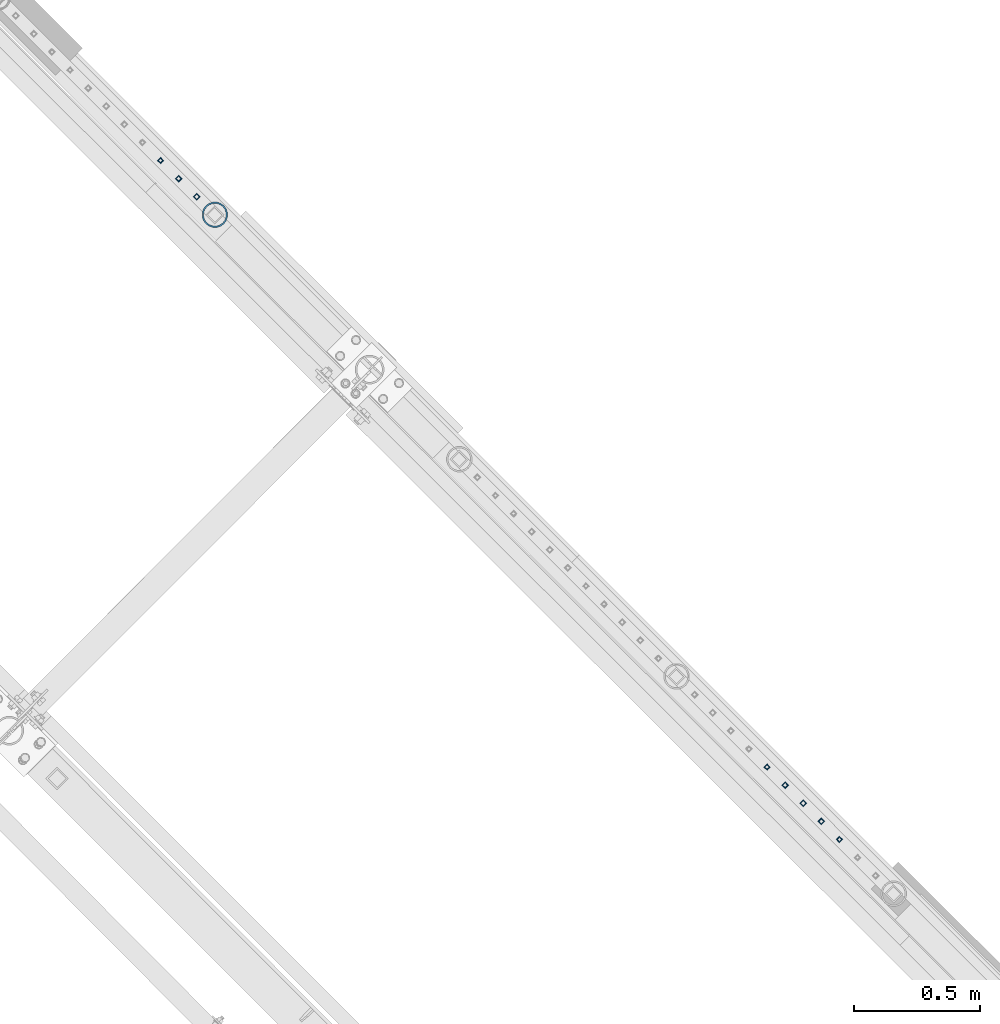
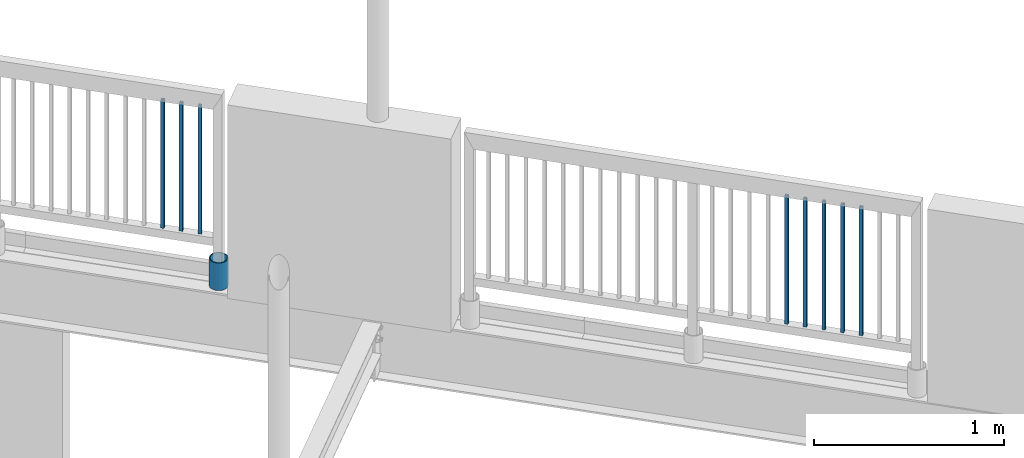
# One storey, part 283 of 975: 9 columns.
"""IFC2X3 building model written with IfcOpenShell, lengths in millimetres."""

import ifcopenshell
import ifcopenshell.guid

model = None  # the IFC model being written
_history = None  # IfcOwnerHistory: only IFC2X3 demands one
_inside = {}  # id of a spatial element -> (the spatial element, [elements in it])
_under = {}  # id of a project, library or spatial element -> (it, [spatial elements below it])
_declared = {}  # id of a project -> (the project, [libraries it declares])
_typed = {}  # id of a type object -> (the type object, [elements of that type])
_made_of = {}  # id of a material, layer set ... -> (it, [elements and type objects made of it])


def new_model(schema):
    """Start an empty IFC model of exactly this schema.

    Asked for "IFC4X3", IfcOpenShell would pick the latest addendum, in which some entities
    have other attributes; the version numbers below select the first issue.
    IFC2X3 requires an IfcOwnerHistory on every rooted entity: one is made here for all.
    """
    global model, _history
    if schema == "IFC4X3":
        model = ifcopenshell.file(schema_version=(4, 3, 0, 0))
    else:
        model = ifcopenshell.file(schema=schema)
    _inside.clear()
    _under.clear()
    _declared.clear()
    _typed.clear()
    _made_of.clear()
    _history = None
    if model.schema == "IFC2X3":
        org = make("IfcOrganization", Name="unknown")
        user = make(
            "IfcPersonAndOrganization",
            ThePerson=make("IfcPerson", FamilyName="unknown"),
            TheOrganization=org,
        )
        app = make(
            "IfcApplication",
            ApplicationDeveloper=org,
            Version="unknown",
            ApplicationFullName="unknown",
            ApplicationIdentifier="unknown",
        )
        _history = make(
            "IfcOwnerHistory",
            OwningUser=user,
            OwningApplication=app,
            ChangeAction="ADDED",
            CreationDate=0,
        )
    return model


def make(cls, **values):
    """One entity of the class cls with the attributes given. An attribute that is None is left unset."""
    return model.create_entity(
        cls, **{name: value for name, value in values.items() if value is not None}
    )


def rooted(cls, **values):
    """An entity with a GlobalId (a new one), such as an element, a storey or a relation."""
    return make(cls, GlobalId=ifcopenshell.guid.new(), OwnerHistory=_history, **values)


def si_unit(unit_type, name, prefix=None):
    """IfcSIUnit, for example si_unit("LENGTHUNIT", "METRE", prefix="MILLI")."""
    return make("IfcSIUnit", UnitType=unit_type, Prefix=prefix, Name=name)


def assignment(units):
    """IfcUnitAssignment: the units of a project."""
    return None if units is None else make("IfcUnitAssignment", Units=units)


def point(xyz):
    """IfcCartesianPoint."""
    return None if xyz is None else make("IfcCartesianPoint", Coordinates=xyz)


def direction(xyz):
    """IfcDirection."""
    return None if xyz is None else make("IfcDirection", DirectionRatios=xyz)


def frame(location, z_axis=None, x_axis=None):
    """IfcAxis2Placement3D, a coordinate frame: its origin and axes. An axis left out is left unset."""
    return make(
        "IfcAxis2Placement3D",
        Location=point(location),
        Axis=direction(z_axis),
        RefDirection=direction(x_axis),
    )


def origin_with_axes():
    """The frame at (0, 0, 0) with the z axis (0, 0, 1) and the x axis (1, 0, 0) written out."""
    return frame((0.0, 0.0, 0.0), z_axis=(0.0, 0.0, 1.0), x_axis=(1.0, 0.0, 0.0))


def place(relative_to, where):
    """IfcLocalPlacement: puts the frame where relative to a parent placement (None: the world)."""
    return make(
        "IfcLocalPlacement", PlacementRelTo=relative_to, RelativePlacement=where
    )


def context(
    kind, dimensions, precision=None, world=None, true_north=None, identifier=None
):
    """IfcGeometricRepresentationContext, for example the 3D "Model" context."""
    return make(
        "IfcGeometricRepresentationContext",
        ContextIdentifier=identifier,
        ContextType=kind,
        CoordinateSpaceDimension=dimensions,
        Precision=precision,
        WorldCoordinateSystem=world,
        TrueNorth=true_north,
    )


def subcontext(parent, identifier, kind, view, scale=None):
    """IfcGeometricRepresentationSubContext, for example "Body" below "Model"."""
    return make(
        "IfcGeometricRepresentationSubContext",
        ContextIdentifier=identifier,
        ContextType=kind,
        ParentContext=parent,
        TargetScale=scale,
        TargetView=view,
    )


def project(units=None, contexts=None):
    """IfcProject with its units and contexts."""
    return rooted(
        "IfcProject",
        Name="project",
        RepresentationContexts=contexts,
        UnitsInContext=assignment(units),
    )


def spatial(cls, under=None, at=None, **own):
    """A site, building, storey or space (cls), placed at a placement, below another one or the project."""
    s = rooted(cls, ObjectPlacement=at, **own)
    if under is not None:
        _under.setdefault(under.id(), (under, []))[1].append(s)
    return s


def faces_of(points, faces, orient=None, outer=None):
    """IfcFace entities. A face is a list of loops; a loop is a list of indices into points, from 0.

    orient and outer hold one flag for each loop. By default every Orientation is true, the
    first loop of a face is its IfcFaceOuterBound and the others are IfcFaceBound.
    """
    made = []
    for i, loops in enumerate(faces):
        bounds = []
        for j, loop in enumerate(loops):
            is_outer = j == 0 if outer is None else outer[i][j]
            bounds.append(
                make(
                    "IfcFaceOuterBound" if is_outer else "IfcFaceBound",
                    Bound=make("IfcPolyLoop", Polygon=[points[k] for k in loop]),
                    Orientation=True if orient is None else orient[i][j],
                )
            )
        made.append(make("IfcFace", Bounds=bounds))
    return made


def faceted_brep(points, faces, orient=None, outer=None, voids=None):
    """IfcFacetedBrep: a solid bounded by flat faces; with voids (closed shells), ...WithVoids."""
    shared = [point(p) for p in points]
    hull = make("IfcClosedShell", CfsFaces=faces_of(shared, faces, orient, outer))
    if voids is None:
        return make("IfcFacetedBrep", Outer=hull)
    return make(
        "IfcFacetedBrepWithVoids",
        Outer=hull,
        Voids=[
            make(cls, CfsFaces=faces_of(shared, fs, o, b)) for cls, fs, o, b in voids
        ],
    )


def shape(context_of_items, identifier, shape_type, items):
    """IfcShapeRepresentation: the items that make up one representation, for example the "Body"."""
    return make(
        "IfcShapeRepresentation",
        ContextOfItems=context_of_items,
        RepresentationIdentifier=identifier,
        RepresentationType=shape_type,
        Items=items,
    )


def material(Name=None, Category=None):
    """IfcMaterial."""
    return make("IfcMaterial", Name=Name, Category=Category)


def made_of(thing, what):
    """Note that an element or type object is made of a material, layer set ...; save() writes the relation."""
    if what is not None:
        _made_of.setdefault(what.id(), (what, []))[1].append(thing)
    return thing


def type_object(cls, material=None, **own):
    """A type object (cls), such as IfcWallType, which elements share."""
    return made_of(rooted(cls, **own), material)


def element(
    cls,
    number,
    at=None,
    inside=None,
    cuts=None,
    type_object=None,
    material=None,
    context=None,
    identifier="Body",
    shape_type=None,
    held_by="IfcProductDefinitionShape",
    body=None,
    shapes=None,
    **own,
):
    """One element of the class cls, such as IfcWall. Its Tag is "e" and its number.

    at: its placement. inside: the storey or other place that contains it. cuts: it is an
    opening in that element (IfcRelVoidsElement). A single representation is given by context,
    identifier, shape_type and body (its items); several are given by shapes. held_by: the class
    of the entity that holds the representations. save() writes the other relations.
    """
    e = rooted(cls, Tag="e%d" % number, ObjectPlacement=at, **own)
    if body is not None:
        shapes = [shape(context, identifier, shape_type, body)]
    if shapes is not None:
        e.Representation = make(held_by, Representations=shapes)
    if inside is not None:
        _inside.setdefault(inside.id(), (inside, []))[1].append(e)
    if cuts is not None:
        rooted(
            "IfcRelVoidsElement", RelatingBuildingElement=cuts, RelatedOpeningElement=e
        )
    if type_object is not None:
        _typed.setdefault(type_object.id(), (type_object, []))[1].append(e)
    return made_of(e, material)


def aggregate(whole, parts):
    """IfcRelAggregates: a whole, such as a stair, and the parts it consists of."""
    return rooted("IfcRelAggregates", RelatingObject=whole, RelatedObjects=parts)


def save(model, path):
    """Write the relations noted so far, then the file.

    IfcRelAggregates (storeys below a building ...), IfcRelContainedInSpatialStructure (elements
    in a storey), IfcRelDefinesByType, IfcRelAssociatesMaterial and IfcRelDeclares: one each for
    every whole, place, type object, material and project.
    """
    for whole, parts in _under.values():
        aggregate(whole, parts)
    for where, things in _inside.values():
        rooted(
            "IfcRelContainedInSpatialStructure",
            RelatedElements=things,
            RelatingStructure=where,
        )
    for kind, things in _typed.values():
        rooted("IfcRelDefinesByType", RelatedObjects=things, RelatingType=kind)
    for what, things in _made_of.values():
        rooted("IfcRelAssociatesMaterial", RelatedObjects=things, RelatingMaterial=what)
    for by, libraries in _declared.values():
        rooted("IfcRelDeclares", RelatingContext=by, RelatedDefinitions=libraries)
    model.write(path)


model = new_model("IFC2X3")

# Units and contexts
model_context = context("Model", 3, precision=1e-05, world=origin_with_axes())
body_context = subcontext(model_context, "Body", "Model", "MODEL_VIEW")
ifc_project = project(units=[si_unit("LENGTHUNIT", "METRE", prefix="MILLI"), si_unit("AREAUNIT", "SQUARE_METRE"), si_unit("VOLUMEUNIT", "CUBIC_METRE"), si_unit("MASSUNIT", "GRAM", prefix="KILO"), si_unit("TIMEUNIT", "SECOND"), si_unit("PLANEANGLEUNIT", "RADIAN"), si_unit("SOLIDANGLEUNIT", "STERADIAN"), si_unit("THERMODYNAMICTEMPERATUREUNIT", "DEGREE_CELSIUS"), si_unit("LUMINOUSINTENSITYUNIT", "LUMEN")], contexts=[model_context])

# Site, building, storey
site_placement = place(None, origin_with_axes())
site = spatial("IfcSite", under=ifc_project, at=site_placement, CompositionType="ELEMENT")
building_placement = place(site_placement, origin_with_axes())
building = spatial("IfcBuilding", under=site, at=building_placement, Name="Undefined", CompositionType="ELEMENT")
storey_placement = place(building_placement, origin_with_axes())
storey = spatial("IfcBuildingStorey", under=building, at=storey_placement, Name="Undefined", CompositionType="ELEMENT", Elevation=0.0)

# Columns
ifc_material_1 = material()
column_type_1 = type_object("IfcColumnType", Name="HSS3/4X3/4X.120_TUBES", PredefinedType="NOTDEFINED")
for number, where, z_axis, x_axis, name in (
    (1, (31713.2852441323, 16921.133183989, 4254.49994796676), (-0.707106781186601, 0.707106781186494, 2.36468622460961e-14), (0.0, 0.0, 1.0), "PICKET"),
    (2, (31785.1196191323, 16849.298808989, 4254.49994796676), (-0.707106781186601, 0.707106781186494, 2.36468622460961e-14), (0.0, 0.0, 1.0), "PICKET"),
    (3, (31856.9539941323, 16777.464433989, 4254.49994796676), (-0.707106781186601, 0.707106781186494, 2.36468622460961e-14), (0.0, 0.0, 1.0), "PICKET"),
    (4, (34119.9673164805, 14514.3285476498, 4254.49994796637), (-0.707106781186601, 0.707106781186494, 2.36468622460961e-14), (0.0, 0.0, 1.0), "PICKET"),
    (5, (34191.8016914805, 14442.4941726498, 4254.49994796637), (-0.707106781186601, 0.707106781186494, 2.36468622460961e-14), (0.0, 0.0, 1.0), "PICKET"),
    (6, (34263.6360664805, 14370.6597976498, 4254.49994796637), (-0.707106781186601, 0.707106781186494, 2.36468622460961e-14), (0.0, 0.0, 1.0), "PICKET"),
    (7, (34335.4704414805, 14298.8254226498, 4254.49994796637), (-0.707106781186601, 0.707106781186494, 2.36468622460961e-14), (0.0, 0.0, 1.0), "PICKET"),
    (8, (34407.3048164805, 14226.9910476498, 4254.49994796637), (-0.707106781186601, 0.707106781186494, 2.36468622460961e-14), (0.0, 0.0, 1.0), "PICKET"),
):
    element("IfcColumn", number, at=place(storey_placement, frame(where, z_axis=z_axis, x_axis=x_axis)), inside=storey, type_object=column_type_1, material=ifc_material_1, Name=name, ObjectType="HSS3/4X3/4X.120_TUBES", context=body_context, shape_type="Brep", body=[
        faceted_brep([(0.0, 6.34999999998763, -6.34999999998763), (0.0, -6.35000000000582, -6.34999999998763), (825.49997943247, -6.35000000000582, -6.34999999998763), (825.49997943247, 6.34999999998763, -6.34999999998763), (0.0, -6.34999999998763, 6.34999999998763), (825.49997943247, -6.34999999998763, 6.34999999998763), (0.0, 6.35000000000946, 6.34999999998763), (825.49997943247, 6.35000000000946, 6.34999999998763), (0.0, 9.52499999997963, -9.52499999997963), (0.0, 9.52500000000873, 9.5249999999869), (825.49997943247, 9.52500000000873, 9.5249999999869), (825.49997943247, 9.52499999997963, -9.52499999997963), (0.0, -9.52499999997963, 9.52499999998327), (825.49997943247, -9.52499999997963, 9.52499999998327), (0.0, -9.52500000000873, -9.5249999999869), (825.49997943247, -9.52500000000873, -9.5249999999869)], [[[0, 1, 2, 3]], [[1, 4, 5, 2]], [[4, 6, 7, 5]], [[6, 0, 3, 7]], [[8, 9, 10, 11]], [[9, 12, 13, 10]], [[12, 14, 15, 13]], [[14, 8, 11, 15]], [[13, 15, 11, 10], [5, 7, 3, 2]], [[14, 12, 9, 8], [6, 4, 1, 0]]]),
    ])
ifc_material_2 = material(Name="STEEL/A53")
column_type_2 = type_object("IfcColumnType", Name="PIPE3-1/2STD", PredefinedType="NOTDEFINED")
column_placement = place(storey_placement, frame((31929.0297813152, 16705.9386942292, 3937.0), z_axis=(-0.707106781186601, 0.707106781186494, 2.36468622460961e-14), x_axis=(0.0, 0.0, 1.0)))
element("IfcColumn", 9, at=column_placement, inside=storey, type_object=column_type_2, material=ifc_material_2, ObjectType="PIPE3-1/2STD", context=body_context, shape_type="Brep", body=[
    faceted_brep([(0.0, -45.0595999999932, 1.45519152283669e-11), (0.0, -42.8542262016344, 13.924182159768), (177.8, -42.8542262016344, 13.924182159768), (177.8, -45.0595999999932, 1.45519152283669e-11), (0.0, -36.45398215971, 26.4853683542424), (177.8, -36.45398215971, 26.4853683542424), (0.0, -26.4853683541623, 36.45398215979), (177.8, -26.4853683541623, 36.45398215979), (0.0, -13.9241821596988, 42.8542262017108), (177.8, -13.9241821596988, 42.8542262017108), (0.0, 3.63797880709171e-11, 45.0596000000514), (177.8, 3.63797880709171e-11, 45.0596000000514), (0.0, 13.9241821597716, 42.8542262017036), (177.8, 13.9241821597716, 42.8542262017036), (0.0, 26.4853683542242, 36.4539821597718), (177.8, 26.4853683542242, 36.4539821597718), (0.0, 36.4539821597537, 26.4853683542206), (177.8, 36.4539821597537, 26.4853683542206), (0.0, 42.8542262016563, 13.9241821597425), (177.8, 42.8542262016563, 13.9241821597425), (0.0, 45.0595999999932, -1.09139364212751e-11), (177.8, 45.0595999999932, -1.09139364212751e-11), (0.0, 42.8542262016344, -13.9241821597643), (177.8, 42.8542262016344, -13.9241821597643), (0.0, 36.45398215971, -26.4853683542387), (177.8, 36.45398215971, -26.4853683542387), (0.0, 26.4853683541623, -36.4539821597864), (177.8, 26.4853683541623, -36.4539821597864), (0.0, 13.9241821596988, -42.8542262017072), (177.8, 13.9241821596988, -42.8542262017072), (0.0, -3.63797880709171e-11, -45.0596000000478), (177.8, -3.63797880709171e-11, -45.0596000000478), (0.0, -13.9241821597716, -42.8542262016963), (177.8, -13.9241821597716, -42.8542262016963), (0.0, -26.4853683542242, -36.4539821597682), (177.8, -26.4853683542242, -36.4539821597682), (0.0, -36.4539821597537, -26.4853683542169), (177.8, -36.4539821597537, -26.4853683542169), (0.0, -42.8542262016563, -13.9241821597352), (177.8, -42.8542262016563, -13.9241821597352), (0.0, -50.799999999992, 1.81898940354586e-11), (0.0, -48.3136710278013, -15.6980633142484), (177.8, -48.3136710278013, -15.6980633142484), (177.8, -50.799999999992, 1.81898940354586e-11), (0.0, -41.0980633142644, -29.8594908164741), (177.8, -41.0980633142644, -29.8594908164741), (0.0, -29.859490816485, -41.0980633142826), (177.8, -29.859490816485, -41.0980633142826), (0.0, -15.6980633142848, -48.313671027845), (177.8, -15.6980633142848, -48.313671027845), (0.0, -4.36557456851006e-11, -50.8000000000575), (177.8, -4.36557456851006e-11, -50.8000000000575), (0.0, 15.6980633142011, -48.3136710278523), (177.8, 15.6980633142011, -48.3136710278523), (0.0, 29.8594908164159, -41.0980633143045), (177.8, 29.8594908164159, -41.0980633143045), (0.0, 41.0980633142135, -29.8594908165032), (177.8, 41.0980633142135, -29.8594908165032), (0.0, 48.3136710277722, -15.6980633142775), (177.8, 48.3136710277722, -15.6980633142775), (0.0, 50.799999999992, -1.45519152283669e-11), (177.8, 50.799999999992, -1.45519152283669e-11), (0.0, 48.313671027794, 15.6980633142521), (177.8, 48.313671027794, 15.6980633142521), (0.0, 41.0980633142644, 29.8594908164814), (177.8, 41.0980633142644, 29.8594908164814), (0.0, 29.859490816485, 41.0980633142863), (177.8, 29.859490816485, 41.0980633142863), (0.0, 15.6980633142848, 48.3136710278486), (177.8, 15.6980633142848, 48.3136710278486), (0.0, 4.00177668780088e-11, 50.8000000000611), (177.8, 4.00177668780088e-11, 50.8000000000611), (0.0, -15.6980633142011, 48.3136710278559), (177.8, -15.6980633142011, 48.3136710278559), (0.0, -29.8594908164159, 41.0980633143081), (177.8, -29.8594908164159, 41.0980633143081), (0.0, -41.0980633142171, 29.8594908165069), (177.8, -41.0980633142171, 29.8594908165069), (0.0, -48.3136710277722, 15.6980633142812), (177.8, -48.3136710277722, 15.6980633142812)], [[[0, 1, 2, 3]], [[1, 4, 5, 2]], [[4, 6, 7, 5]], [[6, 8, 9, 7]], [[8, 10, 11, 9]], [[10, 12, 13, 11]], [[12, 14, 15, 13]], [[14, 16, 17, 15]], [[16, 18, 19, 17]], [[18, 20, 21, 19]], [[20, 22, 23, 21]], [[22, 24, 25, 23]], [[24, 26, 27, 25]], [[26, 28, 29, 27]], [[28, 30, 31, 29]], [[30, 32, 33, 31]], [[32, 34, 35, 33]], [[34, 36, 37, 35]], [[36, 38, 39, 37]], [[38, 0, 3, 39]], [[40, 41, 42, 43]], [[41, 44, 45, 42]], [[44, 46, 47, 45]], [[46, 48, 49, 47]], [[48, 50, 51, 49]], [[50, 52, 53, 51]], [[52, 54, 55, 53]], [[54, 56, 57, 55]], [[56, 58, 59, 57]], [[58, 60, 61, 59]], [[60, 62, 63, 61]], [[62, 64, 65, 63]], [[64, 66, 67, 65]], [[66, 68, 69, 67]], [[68, 70, 71, 69]], [[70, 72, 73, 71]], [[72, 74, 75, 73]], [[74, 76, 77, 75]], [[76, 78, 79, 77]], [[78, 40, 43, 79]], [[45, 47, 49, 51, 53, 55, 57, 59, 61, 63, 65, 67, 69, 71, 73, 75, 77, 79, 43, 42], [5, 7, 9, 11, 13, 15, 17, 19, 21, 23, 25, 27, 29, 31, 33, 35, 37, 39, 3, 2]], [[78, 76, 74, 72, 70, 68, 66, 64, 62, 60, 58, 56, 54, 52, 50, 48, 46, 44, 41, 40], [38, 36, 34, 32, 30, 28, 26, 24, 22, 20, 18, 16, 14, 12, 10, 8, 6, 4, 1, 0]]]),
])

save(model, "model.ifc")
